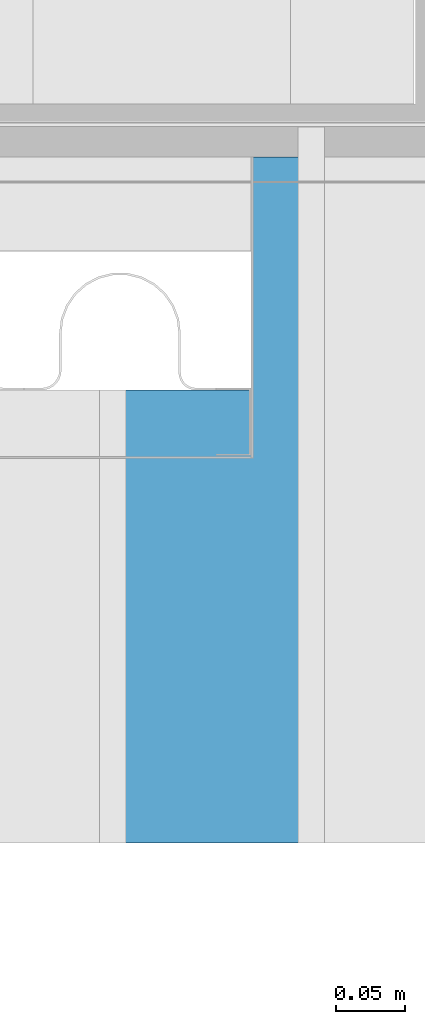
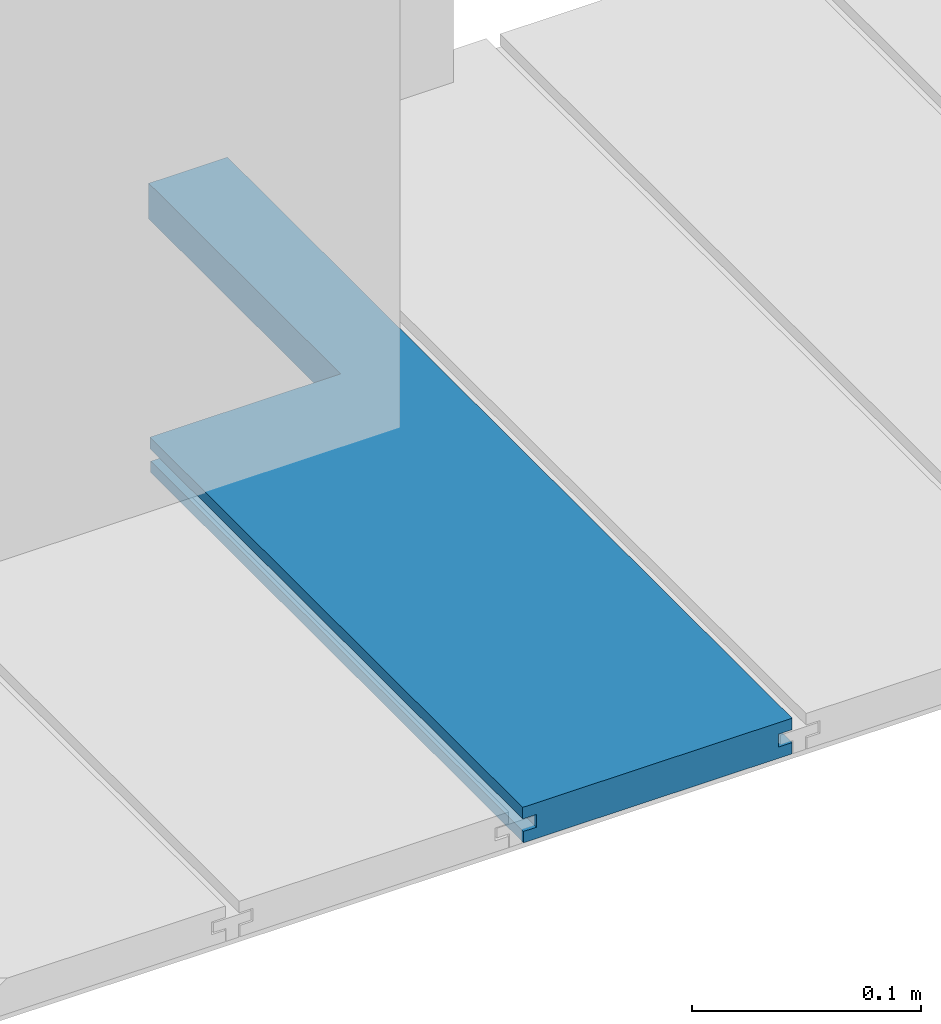
# One storey, part 20 of 33: 1 wall.
"""IFC4 building model written with IfcOpenShell, lengths in feet."""

from ifc_helpers import new_model, entity, si_unit, converted_unit, derived_unit, direction, frame, origin, place, context, subcontext, project, spatial, material, type_object, element, save


model = new_model("IFC4")

# Units and contexts
model_context = context("Model", 3, precision=0.0001, world=origin(), true_north=direction((6.12303176911189e-17, 1.0)))
body_context = subcontext(model_context, "Body", "Model", "MODEL_VIEW")
ifc_project = project(units=[converted_unit("LENGTHUNIT", "FOOT", entity("IfcRatioMeasure", 0.3048), si_unit("LENGTHUNIT", "METRE"), dimensions=[1, 0, 0, 0, 0, 0, 0]), converted_unit("AREAUNIT", "SQUARE FOOT", entity("IfcRatioMeasure", 0.09290304), si_unit("AREAUNIT", "SQUARE_METRE"), dimensions=[2, 0, 0, 0, 0, 0, 0]), converted_unit("VOLUMEUNIT", "CUBIC FOOT", entity("IfcRatioMeasure", 0.028316846592), si_unit("VOLUMEUNIT", "CUBIC_METRE"), dimensions=[3, 0, 0, 0, 0, 0, 0]), converted_unit("PLANEANGLEUNIT", "DEGREE", entity("IfcRatioMeasure", 0.0174532925199433), si_unit("PLANEANGLEUNIT", "RADIAN"), dimensions=[0, 0, 0, 0, 0, 0, 0]), si_unit("MASSUNIT", "GRAM", prefix="KILO"), derived_unit("MASSDENSITYUNIT", [(si_unit("MASSUNIT", "GRAM", prefix="KILO"), 1), (si_unit("LENGTHUNIT", "METRE"), -3)]), derived_unit("MOMENTOFINERTIAUNIT", [(si_unit("LENGTHUNIT", "METRE"), 4)]), si_unit("TIMEUNIT", "SECOND"), si_unit("FREQUENCYUNIT", "HERTZ"), si_unit("THERMODYNAMICTEMPERATUREUNIT", "DEGREE_CELSIUS"), derived_unit("THERMALTRANSMITTANCEUNIT", [(si_unit("MASSUNIT", "GRAM", prefix="KILO"), 1), (si_unit("THERMODYNAMICTEMPERATUREUNIT", "KELVIN"), -1), (si_unit("TIMEUNIT", "SECOND"), -3)]), derived_unit("VOLUMETRICFLOWRATEUNIT", [(si_unit("LENGTHUNIT", "METRE"), 3), (si_unit("TIMEUNIT", "SECOND"), -1)]), si_unit("ELECTRICCURRENTUNIT", "AMPERE"), si_unit("ELECTRICVOLTAGEUNIT", "VOLT"), si_unit("POWERUNIT", "WATT"), si_unit("FORCEUNIT", "NEWTON"), si_unit("ILLUMINANCEUNIT", "LUX"), si_unit("LUMINOUSFLUXUNIT", "LUMEN"), si_unit("LUMINOUSINTENSITYUNIT", "CANDELA"), derived_unit("USERDEFINED", [(si_unit("MASSUNIT", "GRAM", prefix="KILO"), -1), (si_unit("LENGTHUNIT", "METRE"), -2), (si_unit("TIMEUNIT", "SECOND"), 3), (si_unit("LUMINOUSFLUXUNIT", "LUMEN"), 1)]), derived_unit("LINEARVELOCITYUNIT", [(si_unit("LENGTHUNIT", "METRE"), 1), (si_unit("TIMEUNIT", "SECOND"), -1)]), si_unit("PRESSUREUNIT", "PASCAL"), derived_unit("USERDEFINED", [(si_unit("LENGTHUNIT", "METRE"), -2), (si_unit("MASSUNIT", "GRAM", prefix="KILO"), 1), (si_unit("TIMEUNIT", "SECOND"), -2)]), derived_unit("LINEARFORCEUNIT", [(si_unit("MASSUNIT", "GRAM", prefix="KILO"), 1), (si_unit("LENGTHUNIT", "METRE"), 1), (si_unit("TIMEUNIT", "SECOND"), -2), (si_unit("LENGTHUNIT", "METRE"), -1)]), derived_unit("PLANARFORCEUNIT", [(si_unit("MASSUNIT", "GRAM", prefix="KILO"), 1), (si_unit("LENGTHUNIT", "METRE"), 1), (si_unit("TIMEUNIT", "SECOND"), -2), (si_unit("LENGTHUNIT", "METRE"), -2)])], contexts=[model_context])

# Site, building, storey
site_placement = place(None, origin())
site = spatial("IfcSite", under=ifc_project, at=site_placement, CompositionType="ELEMENT")
building_placement = place(site_placement, origin())
building = spatial("IfcBuilding", under=site, at=building_placement, CompositionType="ELEMENT")
storey_placement = place(building_placement, frame((0.0, 0.0, 10.0)))
storey = spatial("IfcBuildingStorey", under=building, at=storey_placement, Name="2ND FLOOR", CompositionType="ELEMENT", Elevation=10.0000000000002)

# Wall
ifc_material = material(Name="COMPOSITE DECKING W/ HIDDEN FASTENERS", Category="Materials")
wall_type = type_object("IfcWallType", Name="Generic Models 686:Generic Models 1", PredefinedType="NOTDEFINED", material=ifc_material)
wall_placement = place(storey_placement, frame((1491.53142284448, 3.0461139299927, 0.682902157150137), z_axis=(0.0, 0.0, 1.0), x_axis=(0.0, 1.0, 0.0)))
cartesian_point_1 = entity("IfcCartesianPoint", [1.62082625651675, -0.446740923891639, 0.0624999999999982])
vertex_point_1 = entity("IfcVertexPoint", cartesian_point_1)
cartesian_point_2 = entity("IfcCartesianPoint", [1.62082625651675, -0.446740923891639, 0.0422987663426522])
vertex_point_2 = entity("IfcVertexPoint", cartesian_point_2)
ifc_direction_1 = entity("IfcDirection", [0.0, 0.0, -1.0])
edge_curve_1 = entity("IfcEdgeCurve", vertex_point_1, vertex_point_2, entity("IfcTrimmedCurve", entity("IfcLine", cartesian_point_1, entity("IfcVector", ifc_direction_1, 1.0)), [cartesian_point_1], [cartesian_point_2], True, "CARTESIAN"), True)
cartesian_point_3 = entity("IfcCartesianPoint", [1.62082625651675, -0.423900922810617, 0.0422987663426504])
vertex_point_3 = entity("IfcVertexPoint", cartesian_point_3)
ifc_direction_2 = entity("IfcDirection", [0.0, 1.0, 0.0])
edge_curve_2 = entity("IfcEdgeCurve", vertex_point_2, vertex_point_3, entity("IfcTrimmedCurve", entity("IfcLine", cartesian_point_2, entity("IfcVector", ifc_direction_2, 1.0)), [cartesian_point_2], [cartesian_point_3], True, "CARTESIAN"), True)
cartesian_point_4 = entity("IfcCartesianPoint", [1.62082625651675, -0.423900922810617, 0.0198779960861462])
vertex_point_4 = entity("IfcVertexPoint", cartesian_point_4)
edge_curve_3 = entity("IfcEdgeCurve", vertex_point_3, vertex_point_4, entity("IfcTrimmedCurve", entity("IfcLine", cartesian_point_3, entity("IfcVector", ifc_direction_1, 1.0)), [cartesian_point_3], [cartesian_point_4], True, "CARTESIAN"), True)
cartesian_point_5 = entity("IfcCartesianPoint", [1.62082625651675, -0.446740923891412, 0.0198779960861479])
vertex_point_5 = entity("IfcVertexPoint", cartesian_point_5)
ifc_direction_3 = entity("IfcDirection", [0.0, -1.0, 0.0])
edge_curve_4 = entity("IfcEdgeCurve", vertex_point_4, vertex_point_5, entity("IfcTrimmedCurve", entity("IfcLine", cartesian_point_4, entity("IfcVector", ifc_direction_3, 1.0)), [cartesian_point_4], [cartesian_point_5], True, "CARTESIAN"), True)
cartesian_point_6 = entity("IfcCartesianPoint", [1.62082625651675, -0.446740923891412, 0.0])
vertex_point_6 = entity("IfcVertexPoint", cartesian_point_6)
edge_curve_5 = entity("IfcEdgeCurve", vertex_point_5, vertex_point_6, entity("IfcTrimmedCurve", entity("IfcLine", cartesian_point_5, entity("IfcVector", ifc_direction_1, 1.0)), [cartesian_point_5], [cartesian_point_6], True, "CARTESIAN"), True)
cartesian_point_7 = entity("IfcCartesianPoint", [1.62082625651675, -0.316142112181524, 0.0])
vertex_point_7 = entity("IfcVertexPoint", cartesian_point_7)
edge_curve_6 = entity("IfcEdgeCurve", vertex_point_6, vertex_point_7, entity("IfcTrimmedCurve", entity("IfcLine", cartesian_point_6, entity("IfcVector", ifc_direction_2, 1.0)), [cartesian_point_6], [cartesian_point_7], True, "CARTESIAN"), True)
cartesian_point_8 = entity("IfcCartesianPoint", [1.62082625651675, -0.316142112181524, 0.0625000000000142])
vertex_point_8 = entity("IfcVertexPoint", cartesian_point_8)
ifc_direction_4 = entity("IfcDirection", [0.0, 0.0, 1.0])
edge_curve_7 = entity("IfcEdgeCurve", vertex_point_7, vertex_point_8, entity("IfcTrimmedCurve", entity("IfcLine", cartesian_point_7, entity("IfcVector", ifc_direction_4, 1.0)), [cartesian_point_7], [cartesian_point_8], True, "CARTESIAN"), True)
edge_curve_8 = entity("IfcEdgeCurve", vertex_point_8, vertex_point_1, entity("IfcTrimmedCurve", entity("IfcLine", cartesian_point_8, entity("IfcVector", ifc_direction_3, 1.0)), [cartesian_point_8], [cartesian_point_1], True, "CARTESIAN"), True)
ifc_direction_5 = entity("IfcDirection", [1.0, 0.0, 0.0])
cartesian_point_9 = entity("IfcCartesianPoint", [0.0, -0.446740923891412, 0.0])
vertex_point_9 = entity("IfcVertexPoint", cartesian_point_9)
cartesian_point_10 = entity("IfcCartesianPoint", [0.0, -0.446740923891412, 0.0198779960861479])
vertex_point_10 = entity("IfcVertexPoint", cartesian_point_10)
edge_curve_9 = entity("IfcEdgeCurve", vertex_point_9, vertex_point_10, entity("IfcTrimmedCurve", entity("IfcLine", cartesian_point_9, entity("IfcVector", ifc_direction_4, 1.0)), [cartesian_point_9], [cartesian_point_10], True, "CARTESIAN"), True)
cartesian_point_11 = entity("IfcCartesianPoint", [0.0, -0.423900922810617, 0.0198779960861462])
vertex_point_11 = entity("IfcVertexPoint", cartesian_point_11)
edge_curve_10 = entity("IfcEdgeCurve", vertex_point_10, vertex_point_11, entity("IfcTrimmedCurve", entity("IfcLine", cartesian_point_10, entity("IfcVector", ifc_direction_2, 1.0)), [cartesian_point_10], [cartesian_point_11], True, "CARTESIAN"), True)
cartesian_point_12 = entity("IfcCartesianPoint", [0.0, -0.423900922810617, 0.0422987663426504])
vertex_point_12 = entity("IfcVertexPoint", cartesian_point_12)
edge_curve_11 = entity("IfcEdgeCurve", vertex_point_11, vertex_point_12, entity("IfcTrimmedCurve", entity("IfcLine", cartesian_point_11, entity("IfcVector", ifc_direction_4, 1.0)), [cartesian_point_11], [cartesian_point_12], True, "CARTESIAN"), True)
cartesian_point_13 = entity("IfcCartesianPoint", [0.0, -0.446740923891639, 0.0422987663426522])
vertex_point_13 = entity("IfcVertexPoint", cartesian_point_13)
edge_curve_12 = entity("IfcEdgeCurve", vertex_point_12, vertex_point_13, entity("IfcTrimmedCurve", entity("IfcLine", cartesian_point_12, entity("IfcVector", ifc_direction_3, 1.0)), [cartesian_point_12], [cartesian_point_13], True, "CARTESIAN"), True)
cartesian_point_14 = entity("IfcCartesianPoint", [0.0, -0.446740923891639, 0.0624999999999982])
vertex_point_14 = entity("IfcVertexPoint", cartesian_point_14)
edge_curve_13 = entity("IfcEdgeCurve", vertex_point_13, vertex_point_14, entity("IfcTrimmedCurve", entity("IfcLine", cartesian_point_13, entity("IfcVector", ifc_direction_4, 1.0)), [cartesian_point_13], [cartesian_point_14], True, "CARTESIAN"), True)
cartesian_point_15 = entity("IfcCartesianPoint", [0.0, 0.0, 0.0625000000000551])
vertex_point_15 = entity("IfcVertexPoint", cartesian_point_15)
edge_curve_14 = entity("IfcEdgeCurve", vertex_point_14, vertex_point_15, entity("IfcTrimmedCurve", entity("IfcLine", cartesian_point_14, entity("IfcVector", ifc_direction_2, 1.0)), [cartesian_point_14], [cartesian_point_15], True, "CARTESIAN"), True)
cartesian_point_16 = entity("IfcCartesianPoint", [0.0, 0.0, 0.0422987663426522])
vertex_point_16 = entity("IfcVertexPoint", cartesian_point_16)
edge_curve_15 = entity("IfcEdgeCurve", vertex_point_15, vertex_point_16, entity("IfcTrimmedCurve", entity("IfcLine", cartesian_point_15, entity("IfcVector", ifc_direction_1, 1.0)), [cartesian_point_15], [cartesian_point_16], True, "CARTESIAN"), True)
cartesian_point_17 = entity("IfcCartesianPoint", [0.0, -0.0228400010807945, 0.0422987663426504])
vertex_point_17 = entity("IfcVertexPoint", cartesian_point_17)
edge_curve_16 = entity("IfcEdgeCurve", vertex_point_16, vertex_point_17, entity("IfcTrimmedCurve", entity("IfcLine", cartesian_point_16, entity("IfcVector", ifc_direction_3, 1.0)), [cartesian_point_16], [cartesian_point_17], True, "CARTESIAN"), True)
cartesian_point_18 = entity("IfcCartesianPoint", [0.0, -0.0228400010807945, 0.0198779960861462])
vertex_point_18 = entity("IfcVertexPoint", cartesian_point_18)
edge_curve_17 = entity("IfcEdgeCurve", vertex_point_17, vertex_point_18, entity("IfcTrimmedCurve", entity("IfcLine", cartesian_point_17, entity("IfcVector", ifc_direction_1, 1.0)), [cartesian_point_17], [cartesian_point_18], True, "CARTESIAN"), True)
cartesian_point_19 = entity("IfcCartesianPoint", [0.0, -0.00132475379450625, 0.0198779960861479])
vertex_point_19 = entity("IfcVertexPoint", cartesian_point_19)
edge_curve_18 = entity("IfcEdgeCurve", vertex_point_18, vertex_point_19, entity("IfcTrimmedCurve", entity("IfcLine", cartesian_point_18, entity("IfcVector", ifc_direction_2, 1.0)), [cartesian_point_18], [cartesian_point_19], True, "CARTESIAN"), True)
cartesian_point_20 = entity("IfcCartesianPoint", [0.0, -0.00132475379450625, 0.0])
vertex_point_20 = entity("IfcVertexPoint", cartesian_point_20)
edge_curve_19 = entity("IfcEdgeCurve", vertex_point_19, vertex_point_20, entity("IfcTrimmedCurve", entity("IfcLine", cartesian_point_19, entity("IfcVector", ifc_direction_1, 1.0)), [cartesian_point_19], [cartesian_point_20], True, "CARTESIAN"), True)
edge_curve_20 = entity("IfcEdgeCurve", vertex_point_20, vertex_point_9, entity("IfcTrimmedCurve", entity("IfcLine", cartesian_point_20, entity("IfcVector", ifc_direction_3, 1.0)), [cartesian_point_20], [cartesian_point_9], True, "CARTESIAN"), True)
ifc_direction_6 = entity("IfcDirection", [-1.0, 0.0, 0.0])
edge_curve_21 = entity("IfcEdgeCurve", vertex_point_5, vertex_point_10, entity("IfcTrimmedCurve", entity("IfcLine", cartesian_point_10, entity("IfcVector", ifc_direction_6, 1.0)), [cartesian_point_5], [cartesian_point_10], True, "CARTESIAN"), True)
edge_curve_22 = entity("IfcEdgeCurve", vertex_point_9, vertex_point_6, entity("IfcTrimmedCurve", entity("IfcLine", cartesian_point_9, entity("IfcVector", ifc_direction_5, 1.0)), [cartesian_point_9], [cartesian_point_6], True, "CARTESIAN"), True)
edge_curve_23 = entity("IfcEdgeCurve", vertex_point_14, vertex_point_1, entity("IfcTrimmedCurve", entity("IfcLine", cartesian_point_14, entity("IfcVector", ifc_direction_5, 1.0)), [cartesian_point_14], [cartesian_point_1], True, "CARTESIAN"), True)
cartesian_point_21 = entity("IfcCartesianPoint", [1.07004500651836, -0.316142112181524, 0.0625000000000142])
vertex_point_21 = entity("IfcVertexPoint", cartesian_point_21)
edge_curve_24 = entity("IfcEdgeCurve", vertex_point_8, vertex_point_21, entity("IfcTrimmedCurve", entity("IfcLine", cartesian_point_8, entity("IfcVector", ifc_direction_6, 1.0)), [cartesian_point_8], [cartesian_point_21], True, "CARTESIAN"), True)
cartesian_point_22 = entity("IfcCartesianPoint", [1.07004500651836, 0.0, 0.0625000000000551])
vertex_point_22 = entity("IfcVertexPoint", cartesian_point_22)
edge_curve_25 = entity("IfcEdgeCurve", vertex_point_21, vertex_point_22, entity("IfcTrimmedCurve", entity("IfcLine", cartesian_point_21, entity("IfcVector", ifc_direction_2, 1.0)), [cartesian_point_21], [cartesian_point_22], True, "CARTESIAN"), True)
edge_curve_26 = entity("IfcEdgeCurve", vertex_point_22, vertex_point_15, entity("IfcTrimmedCurve", entity("IfcLine", cartesian_point_15, entity("IfcVector", ifc_direction_6, 1.0)), [cartesian_point_22], [cartesian_point_15], True, "CARTESIAN"), True)
cartesian_point_23 = entity("IfcCartesianPoint", [1.07004500651836, 0.0, 0.0422987663426522])
vertex_point_23 = entity("IfcVertexPoint", cartesian_point_23)
edge_curve_27 = entity("IfcEdgeCurve", vertex_point_22, vertex_point_23, entity("IfcTrimmedCurve", entity("IfcLine", cartesian_point_22, entity("IfcVector", ifc_direction_1, 1.0)), [cartesian_point_22], [cartesian_point_23], True, "CARTESIAN"), True)
edge_curve_28 = entity("IfcEdgeCurve", vertex_point_23, vertex_point_16, entity("IfcTrimmedCurve", entity("IfcLine", cartesian_point_16, entity("IfcVector", ifc_direction_6, 1.0)), [cartesian_point_23], [cartesian_point_16], True, "CARTESIAN"), True)
cartesian_point_24 = entity("IfcCartesianPoint", [1.07004500651836, -0.00132475379450625, 0.0])
vertex_point_24 = entity("IfcVertexPoint", cartesian_point_24)
edge_curve_29 = entity("IfcEdgeCurve", vertex_point_20, vertex_point_24, entity("IfcTrimmedCurve", entity("IfcLine", cartesian_point_20, entity("IfcVector", ifc_direction_5, 1.0)), [cartesian_point_20], [cartesian_point_24], True, "CARTESIAN"), True)
cartesian_point_25 = entity("IfcCartesianPoint", [1.07004500651836, -0.316142112181751, 0.0])
vertex_point_25 = entity("IfcVertexPoint", cartesian_point_25)
edge_curve_30 = entity("IfcEdgeCurve", vertex_point_24, vertex_point_25, entity("IfcTrimmedCurve", entity("IfcLine", cartesian_point_24, entity("IfcVector", ifc_direction_3, 1.0)), [cartesian_point_24], [cartesian_point_25], True, "CARTESIAN"), True)
edge_curve_31 = entity("IfcEdgeCurve", vertex_point_25, vertex_point_7, entity("IfcTrimmedCurve", entity("IfcLine", cartesian_point_25, entity("IfcVector", ifc_direction_5, 1.0)), [cartesian_point_25], [cartesian_point_7], True, "CARTESIAN"), True)
edge_curve_32 = entity("IfcEdgeCurve", vertex_point_13, vertex_point_2, entity("IfcTrimmedCurve", entity("IfcLine", cartesian_point_13, entity("IfcVector", ifc_direction_5, 1.0)), [cartesian_point_13], [cartesian_point_2], True, "CARTESIAN"), True)
cartesian_point_26 = entity("IfcCartesianPoint", [1.07004500651836, -0.0228400010807945, 0.0422987663426504])
vertex_point_26 = entity("IfcVertexPoint", cartesian_point_26)
edge_curve_33 = entity("IfcEdgeCurve", vertex_point_23, vertex_point_26, entity("IfcTrimmedCurve", entity("IfcLine", cartesian_point_23, entity("IfcVector", ifc_direction_3, 1.0)), [cartesian_point_23], [cartesian_point_26], True, "CARTESIAN"), True)
edge_curve_34 = entity("IfcEdgeCurve", vertex_point_26, vertex_point_17, entity("IfcTrimmedCurve", entity("IfcLine", cartesian_point_17, entity("IfcVector", ifc_direction_6, 1.0)), [cartesian_point_26], [cartesian_point_17], True, "CARTESIAN"), True)
cartesian_point_27 = entity("IfcCartesianPoint", [1.07004500651836, -0.0228400010807945, 0.0198779960861462])
vertex_point_27 = entity("IfcVertexPoint", cartesian_point_27)
edge_curve_35 = entity("IfcEdgeCurve", vertex_point_26, vertex_point_27, entity("IfcTrimmedCurve", entity("IfcLine", cartesian_point_26, entity("IfcVector", ifc_direction_1, 1.0)), [cartesian_point_26], [cartesian_point_27], True, "CARTESIAN"), True)
edge_curve_36 = entity("IfcEdgeCurve", vertex_point_27, vertex_point_18, entity("IfcTrimmedCurve", entity("IfcLine", cartesian_point_18, entity("IfcVector", ifc_direction_6, 1.0)), [cartesian_point_27], [cartesian_point_18], True, "CARTESIAN"), True)
cartesian_point_28 = entity("IfcCartesianPoint", [1.07004500651836, -0.00132475379450625, 0.0198779960861479])
vertex_point_28 = entity("IfcVertexPoint", cartesian_point_28)
edge_curve_37 = entity("IfcEdgeCurve", vertex_point_27, vertex_point_28, entity("IfcTrimmedCurve", entity("IfcLine", cartesian_point_27, entity("IfcVector", ifc_direction_2, 1.0)), [cartesian_point_27], [cartesian_point_28], True, "CARTESIAN"), True)
edge_curve_38 = entity("IfcEdgeCurve", vertex_point_28, vertex_point_19, entity("IfcTrimmedCurve", entity("IfcLine", cartesian_point_19, entity("IfcVector", ifc_direction_6, 1.0)), [cartesian_point_28], [cartesian_point_19], True, "CARTESIAN"), True)
edge_curve_39 = entity("IfcEdgeCurve", vertex_point_28, vertex_point_24, entity("IfcTrimmedCurve", entity("IfcLine", cartesian_point_28, entity("IfcVector", ifc_direction_1, 1.0)), [cartesian_point_28], [cartesian_point_24], True, "CARTESIAN"), True)
edge_curve_40 = entity("IfcEdgeCurve", vertex_point_4, vertex_point_11, entity("IfcTrimmedCurve", entity("IfcLine", cartesian_point_11, entity("IfcVector", ifc_direction_6, 1.0)), [cartesian_point_4], [cartesian_point_11], True, "CARTESIAN"), True)
edge_curve_41 = entity("IfcEdgeCurve", vertex_point_3, vertex_point_12, entity("IfcTrimmedCurve", entity("IfcLine", cartesian_point_12, entity("IfcVector", ifc_direction_6, 1.0)), [cartesian_point_3], [cartesian_point_12], True, "CARTESIAN"), True)
edge_curve_42 = entity("IfcEdgeCurve", vertex_point_21, vertex_point_25, entity("IfcTrimmedCurve", entity("IfcLine", cartesian_point_21, entity("IfcVector", ifc_direction_1, 1.0)), [cartesian_point_21], [cartesian_point_25], True, "CARTESIAN"), True)
element("IfcWall", 1, at=wall_placement, inside=storey, type_object=wall_type, material=ifc_material, Name="Generic Models 686:Generic Models 1", ObjectType="Generic Models 686:Generic Models 1", PredefinedType="NOTDEFINED", context=body_context, shape_type="AdvancedBrep", body=[
    entity("IfcAdvancedBrep", entity("IfcClosedShell", [entity("IfcAdvancedFace", [entity("IfcFaceOuterBound", entity("IfcEdgeLoop", [entity("IfcOrientedEdge", None, None, edge_curve_1, True), entity("IfcOrientedEdge", None, None, edge_curve_2, True), entity("IfcOrientedEdge", None, None, edge_curve_3, True), entity("IfcOrientedEdge", None, None, edge_curve_4, True), entity("IfcOrientedEdge", None, None, edge_curve_5, True), entity("IfcOrientedEdge", None, None, edge_curve_6, True), entity("IfcOrientedEdge", None, None, edge_curve_7, True), entity("IfcOrientedEdge", None, None, edge_curve_8, True)]), True)], entity("IfcPlane", entity("IfcAxis2Placement3D", entity("IfcCartesianPoint", [1.62082625651675, -0.446740923891412, -0.0208333333328241]), ifc_direction_5, ifc_direction_1)), True), entity("IfcAdvancedFace", [entity("IfcFaceOuterBound", entity("IfcEdgeLoop", [entity("IfcOrientedEdge", None, None, edge_curve_9, True), entity("IfcOrientedEdge", None, None, edge_curve_10, True), entity("IfcOrientedEdge", None, None, edge_curve_11, True), entity("IfcOrientedEdge", None, None, edge_curve_12, True), entity("IfcOrientedEdge", None, None, edge_curve_13, True), entity("IfcOrientedEdge", None, None, edge_curve_14, True), entity("IfcOrientedEdge", None, None, edge_curve_15, True), entity("IfcOrientedEdge", None, None, edge_curve_16, True), entity("IfcOrientedEdge", None, None, edge_curve_17, True), entity("IfcOrientedEdge", None, None, edge_curve_18, True), entity("IfcOrientedEdge", None, None, edge_curve_19, True), entity("IfcOrientedEdge", None, None, edge_curve_20, True)]), True)], entity("IfcPlane", entity("IfcAxis2Placement3D", entity("IfcCartesianPoint", [0.0, -0.446740923891412, -0.0208333333328241]), ifc_direction_6, ifc_direction_4)), True), entity("IfcAdvancedFace", [entity("IfcFaceOuterBound", entity("IfcEdgeLoop", [entity("IfcOrientedEdge", None, None, edge_curve_5, False), entity("IfcOrientedEdge", None, None, edge_curve_21, True), entity("IfcOrientedEdge", None, None, edge_curve_9, False), entity("IfcOrientedEdge", None, None, edge_curve_22, True)]), True)], entity("IfcPlane", entity("IfcAxis2Placement3D", cartesian_point_9, ifc_direction_3, ifc_direction_5)), True), entity("IfcAdvancedFace", [entity("IfcFaceOuterBound", entity("IfcEdgeLoop", [entity("IfcOrientedEdge", None, None, edge_curve_14, False), entity("IfcOrientedEdge", None, None, edge_curve_23, True), entity("IfcOrientedEdge", None, None, edge_curve_8, False), entity("IfcOrientedEdge", None, None, edge_curve_24, True), entity("IfcOrientedEdge", None, None, edge_curve_25, True), entity("IfcOrientedEdge", None, None, edge_curve_26, True)]), True)], entity("IfcPlane", entity("IfcAxis2Placement3D", cartesian_point_14, ifc_direction_4, ifc_direction_5)), True), entity("IfcAdvancedFace", [entity("IfcFaceOuterBound", entity("IfcEdgeLoop", [entity("IfcOrientedEdge", None, None, edge_curve_15, False), entity("IfcOrientedEdge", None, None, edge_curve_26, False), entity("IfcOrientedEdge", None, None, edge_curve_27, True), entity("IfcOrientedEdge", None, None, edge_curve_28, True)]), True)], entity("IfcPlane", entity("IfcAxis2Placement3D", cartesian_point_15, ifc_direction_2, ifc_direction_5)), True), entity("IfcAdvancedFace", [entity("IfcFaceOuterBound", entity("IfcEdgeLoop", [entity("IfcOrientedEdge", None, None, edge_curve_20, False), entity("IfcOrientedEdge", None, None, edge_curve_29, True), entity("IfcOrientedEdge", None, None, edge_curve_30, True), entity("IfcOrientedEdge", None, None, edge_curve_31, True), entity("IfcOrientedEdge", None, None, edge_curve_6, False), entity("IfcOrientedEdge", None, None, edge_curve_22, False)]), True)], entity("IfcPlane", entity("IfcAxis2Placement3D", cartesian_point_20, ifc_direction_1, ifc_direction_5)), True), entity("IfcAdvancedFace", [entity("IfcFaceOuterBound", entity("IfcEdgeLoop", [entity("IfcOrientedEdge", None, None, edge_curve_1, False), entity("IfcOrientedEdge", None, None, edge_curve_23, False), entity("IfcOrientedEdge", None, None, edge_curve_13, False), entity("IfcOrientedEdge", None, None, edge_curve_32, True)]), True)], entity("IfcPlane", entity("IfcAxis2Placement3D", cartesian_point_13, ifc_direction_3, ifc_direction_5)), True), entity("IfcAdvancedFace", [entity("IfcFaceOuterBound", entity("IfcEdgeLoop", [entity("IfcOrientedEdge", None, None, edge_curve_16, False), entity("IfcOrientedEdge", None, None, edge_curve_28, False), entity("IfcOrientedEdge", None, None, edge_curve_33, True), entity("IfcOrientedEdge", None, None, edge_curve_34, True)]), True)], entity("IfcPlane", entity("IfcAxis2Placement3D", cartesian_point_16, ifc_direction_1, ifc_direction_5)), True), entity("IfcAdvancedFace", [entity("IfcFaceOuterBound", entity("IfcEdgeLoop", [entity("IfcOrientedEdge", None, None, edge_curve_17, False), entity("IfcOrientedEdge", None, None, edge_curve_34, False), entity("IfcOrientedEdge", None, None, edge_curve_35, True), entity("IfcOrientedEdge", None, None, edge_curve_36, True)]), True)], entity("IfcPlane", entity("IfcAxis2Placement3D", cartesian_point_17, ifc_direction_2, ifc_direction_5)), True), entity("IfcAdvancedFace", [entity("IfcFaceOuterBound", entity("IfcEdgeLoop", [entity("IfcOrientedEdge", None, None, edge_curve_18, False), entity("IfcOrientedEdge", None, None, edge_curve_36, False), entity("IfcOrientedEdge", None, None, edge_curve_37, True), entity("IfcOrientedEdge", None, None, edge_curve_38, True)]), True)], entity("IfcPlane", entity("IfcAxis2Placement3D", cartesian_point_18, ifc_direction_4, ifc_direction_5)), True), entity("IfcAdvancedFace", [entity("IfcFaceOuterBound", entity("IfcEdgeLoop", [entity("IfcOrientedEdge", None, None, edge_curve_19, False), entity("IfcOrientedEdge", None, None, edge_curve_38, False), entity("IfcOrientedEdge", None, None, edge_curve_39, True), entity("IfcOrientedEdge", None, None, edge_curve_29, False)]), True)], entity("IfcPlane", entity("IfcAxis2Placement3D", cartesian_point_19, ifc_direction_2, ifc_direction_5)), True), entity("IfcAdvancedFace", [entity("IfcFaceOuterBound", entity("IfcEdgeLoop", [entity("IfcOrientedEdge", None, None, edge_curve_4, False), entity("IfcOrientedEdge", None, None, edge_curve_40, True), entity("IfcOrientedEdge", None, None, edge_curve_10, False), entity("IfcOrientedEdge", None, None, edge_curve_21, False)]), True)], entity("IfcPlane", entity("IfcAxis2Placement3D", cartesian_point_10, ifc_direction_4, ifc_direction_5)), True), entity("IfcAdvancedFace", [entity("IfcFaceOuterBound", entity("IfcEdgeLoop", [entity("IfcOrientedEdge", None, None, edge_curve_3, False), entity("IfcOrientedEdge", None, None, edge_curve_41, True), entity("IfcOrientedEdge", None, None, edge_curve_11, False), entity("IfcOrientedEdge", None, None, edge_curve_40, False)]), True)], entity("IfcPlane", entity("IfcAxis2Placement3D", cartesian_point_11, ifc_direction_3, ifc_direction_5)), True), entity("IfcAdvancedFace", [entity("IfcFaceOuterBound", entity("IfcEdgeLoop", [entity("IfcOrientedEdge", None, None, edge_curve_2, False), entity("IfcOrientedEdge", None, None, edge_curve_32, False), entity("IfcOrientedEdge", None, None, edge_curve_12, False), entity("IfcOrientedEdge", None, None, edge_curve_41, False)]), True)], entity("IfcPlane", entity("IfcAxis2Placement3D", cartesian_point_12, ifc_direction_1, ifc_direction_5)), True), entity("IfcAdvancedFace", [entity("IfcFaceOuterBound", entity("IfcEdgeLoop", [entity("IfcOrientedEdge", None, None, edge_curve_42, True), entity("IfcOrientedEdge", None, None, edge_curve_30, False), entity("IfcOrientedEdge", None, None, edge_curve_39, False), entity("IfcOrientedEdge", None, None, edge_curve_37, False), entity("IfcOrientedEdge", None, None, edge_curve_35, False), entity("IfcOrientedEdge", None, None, edge_curve_33, False), entity("IfcOrientedEdge", None, None, edge_curve_27, False), entity("IfcOrientedEdge", None, None, edge_curve_25, False)]), True)], entity("IfcPlane", entity("IfcAxis2Placement3D", entity("IfcCartesianPoint", [1.07004500651836, -0.316142112181524, -0.520833333333311]), ifc_direction_5, ifc_direction_4)), True), entity("IfcAdvancedFace", [entity("IfcFaceOuterBound", entity("IfcEdgeLoop", [entity("IfcOrientedEdge", None, None, edge_curve_42, False), entity("IfcOrientedEdge", None, None, edge_curve_24, False), entity("IfcOrientedEdge", None, None, edge_curve_7, False), entity("IfcOrientedEdge", None, None, edge_curve_31, False)]), True)], entity("IfcPlane", entity("IfcAxis2Placement3D", entity("IfcCartesianPoint", [1.74626237161069, -0.316142112181524, -0.520833333333311]), ifc_direction_2, ifc_direction_4)), True)])),
])

save(model, "model.ifc")
